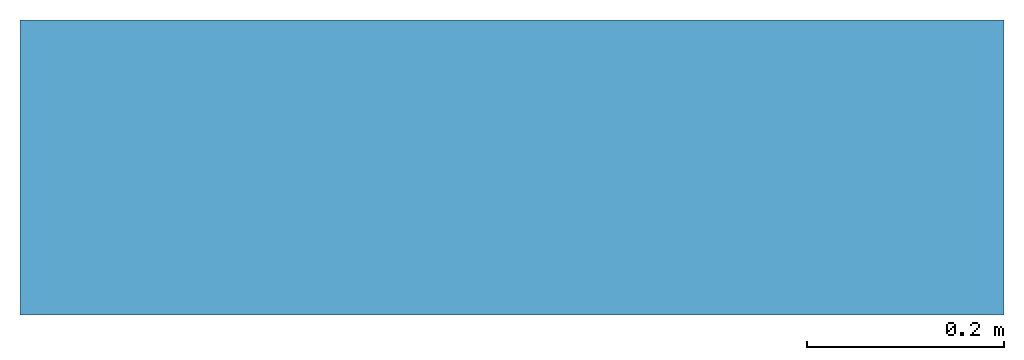
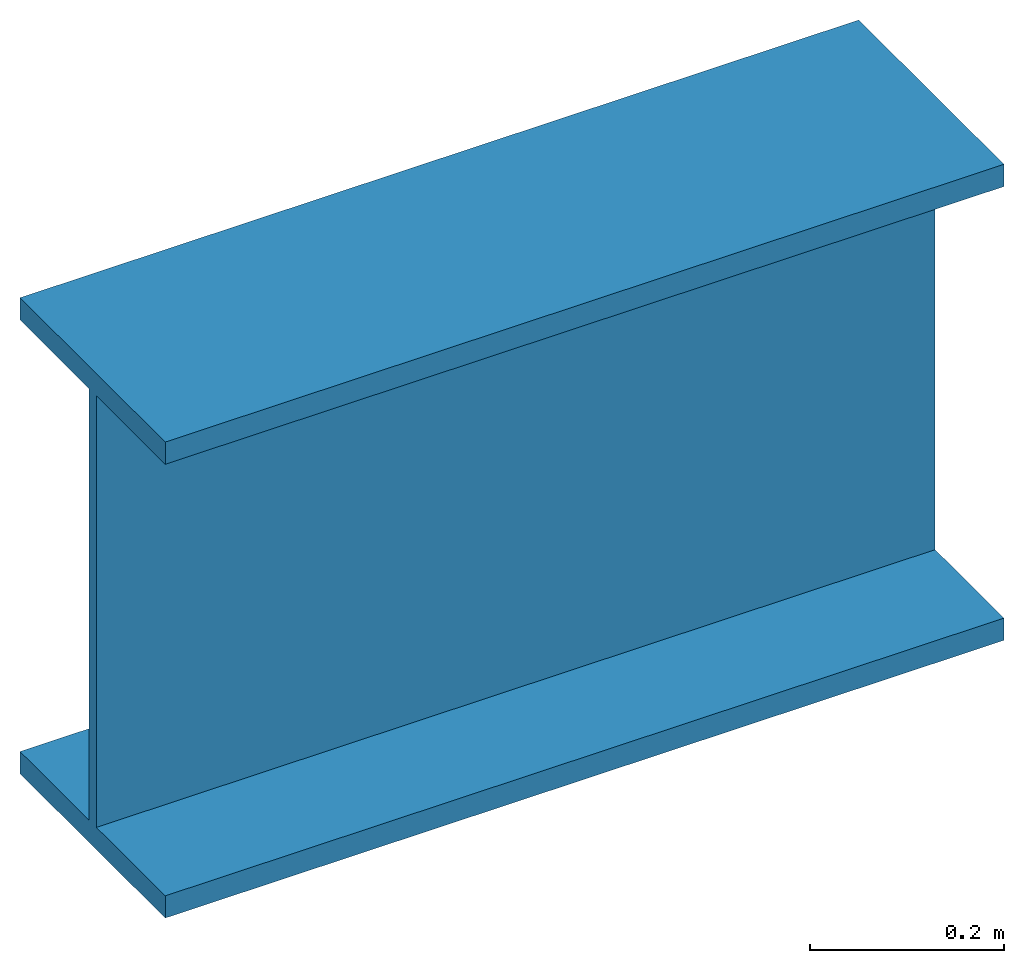
# Not in any storey: 1 beam.
"""IFC4 model written with IfcOpenShell, lengths in metres."""

import ifcopenshell
import ifcopenshell.guid

model = None  # the IFC model being written
_history = None  # IfcOwnerHistory: only IFC2X3 demands one
_inside = {}  # id of a spatial element -> (the spatial element, [elements in it])
_under = {}  # id of a project, library or spatial element -> (it, [spatial elements below it])
_declared = {}  # id of a project -> (the project, [libraries it declares])
_typed = {}  # id of a type object -> (the type object, [elements of that type])
_made_of = {}  # id of a material, layer set ... -> (it, [elements and type objects made of it])


def new_model(schema):
    """Start an empty IFC model of exactly this schema.

    Asked for "IFC4X3", IfcOpenShell would pick the latest addendum, in which some entities
    have other attributes; the version numbers below select the first issue.
    IFC2X3 requires an IfcOwnerHistory on every rooted entity: one is made here for all.
    """
    global model, _history
    if schema == "IFC4X3":
        model = ifcopenshell.file(schema_version=(4, 3, 0, 0))
    else:
        model = ifcopenshell.file(schema=schema)
    _inside.clear()
    _under.clear()
    _declared.clear()
    _typed.clear()
    _made_of.clear()
    _history = None
    if model.schema == "IFC2X3":
        org = make("IfcOrganization", Name="unknown")
        user = make(
            "IfcPersonAndOrganization",
            ThePerson=make("IfcPerson", FamilyName="unknown"),
            TheOrganization=org,
        )
        app = make(
            "IfcApplication",
            ApplicationDeveloper=org,
            Version="unknown",
            ApplicationFullName="unknown",
            ApplicationIdentifier="unknown",
        )
        _history = make(
            "IfcOwnerHistory",
            OwningUser=user,
            OwningApplication=app,
            ChangeAction="ADDED",
            CreationDate=0,
        )
    return model


def make(cls, **values):
    """One entity of the class cls with the attributes given. An attribute that is None is left unset."""
    return model.create_entity(
        cls, **{name: value for name, value in values.items() if value is not None}
    )


def entity(cls, *values):
    """Any entity or typed value of the class cls, its attributes in the order of the schema. None: left unset."""
    e = model.create_entity(cls)
    for i, value in enumerate(values):
        if value is not None:
            e[i] = value
    return e


def rooted(cls, **values):
    """An entity with a GlobalId (a new one), such as an element, a storey or a relation."""
    return make(cls, GlobalId=ifcopenshell.guid.new(), OwnerHistory=_history, **values)


def si_unit(unit_type, name, prefix=None):
    """IfcSIUnit, for example si_unit("LENGTHUNIT", "METRE", prefix="MILLI")."""
    return make("IfcSIUnit", UnitType=unit_type, Prefix=prefix, Name=name)


def converted_unit(unit_type, name, factor, base, dimensions=None, offset=None):
    """IfcConversionBasedUnit, such as the inch: factor (a typed value) times the base unit."""
    return make(
        "IfcConversionBasedUnit"
        if offset is None
        else "IfcConversionBasedUnitWithOffset",
        ConversionOffset=offset,
        Dimensions=None
        if dimensions is None
        else entity("IfcDimensionalExponents", *dimensions),
        UnitType=unit_type,
        Name=name,
        ConversionFactor=make(
            "IfcMeasureWithUnit", ValueComponent=factor, UnitComponent=base
        ),
    )


def derived_unit(unit_type, elements):
    """IfcDerivedUnit: a product of units, each with its exponent."""
    return make(
        "IfcDerivedUnit",
        Elements=[
            make("IfcDerivedUnitElement", Unit=unit, Exponent=power)
            for unit, power in elements
        ],
        UnitType=unit_type,
    )


def assignment(units):
    """IfcUnitAssignment: the units of a project."""
    return None if units is None else make("IfcUnitAssignment", Units=units)


def point(xyz):
    """IfcCartesianPoint."""
    return None if xyz is None else make("IfcCartesianPoint", Coordinates=xyz)


def direction(xyz):
    """IfcDirection."""
    return None if xyz is None else make("IfcDirection", DirectionRatios=xyz)


def frame(location, z_axis=None, x_axis=None):
    """IfcAxis2Placement3D, a coordinate frame: its origin and axes. An axis left out is left unset."""
    return make(
        "IfcAxis2Placement3D",
        Location=point(location),
        Axis=direction(z_axis),
        RefDirection=direction(x_axis),
    )


def frame_2d(location, x_axis=None):
    """IfcAxis2Placement2D, a coordinate frame in the plane: its origin and x axis."""
    return make(
        "IfcAxis2Placement2D", Location=point(location), RefDirection=direction(x_axis)
    )


def origin():
    """The frame at (0, 0, 0) with its axes left unset."""
    return frame((0.0, 0.0, 0.0))


def place(relative_to, where):
    """IfcLocalPlacement: puts the frame where relative to a parent placement (None: the world)."""
    return make(
        "IfcLocalPlacement", PlacementRelTo=relative_to, RelativePlacement=where
    )


def context(
    kind, dimensions, precision=None, world=None, true_north=None, identifier=None
):
    """IfcGeometricRepresentationContext, for example the 3D "Model" context."""
    return make(
        "IfcGeometricRepresentationContext",
        ContextIdentifier=identifier,
        ContextType=kind,
        CoordinateSpaceDimension=dimensions,
        Precision=precision,
        WorldCoordinateSystem=world,
        TrueNorth=true_north,
    )


def subcontext(parent, identifier, kind, view, scale=None):
    """IfcGeometricRepresentationSubContext, for example "Body" below "Model"."""
    return make(
        "IfcGeometricRepresentationSubContext",
        ContextIdentifier=identifier,
        ContextType=kind,
        ParentContext=parent,
        TargetScale=scale,
        TargetView=view,
    )


def project(units=None, contexts=None):
    """IfcProject with its units and contexts."""
    return rooted(
        "IfcProject",
        Name="project",
        RepresentationContexts=contexts,
        UnitsInContext=assignment(units),
    )


def spatial(cls, under=None, at=None, **own):
    """A site, building, storey or space (cls), placed at a placement, below another one or the project."""
    s = rooted(cls, ObjectPlacement=at, **own)
    if under is not None:
        _under.setdefault(under.id(), (under, []))[1].append(s)
    return s


def polyline(points):
    """IfcPolyline through the points."""
    return make("IfcPolyline", Points=[point(p) for p in points])


def segment(curve, same_sense, transition):
    """IfcCompositeCurveSegment."""
    return make(
        "IfcCompositeCurveSegment",
        Transition=transition,
        SameSense=same_sense,
        ParentCurve=curve,
    )


def composite_curve(segments, self_intersect=None):
    """IfcCompositeCurve: segments joined end to end."""
    return make("IfcCompositeCurve", Segments=segments, SelfIntersect=self_intersect)


def profile(cls, at=None, kind="AREA", **sizes):
    """A parametric profile (cls). Its sizes go by their IFC names, for example OverallWidth=200.0."""
    return make(cls, ProfileType=kind, Position=at, **sizes)


def i_section(**sizes):
    """IfcIShapeProfileDef."""
    return profile("IfcIShapeProfileDef", **sizes)


def outline(outer, holes=None, kind="AREA"):
    """IfcArbitraryClosedProfileDef: a profile drawn as a closed curve; with holes, ...WithVoids."""
    if holes is None:
        return make("IfcArbitraryClosedProfileDef", ProfileType=kind, OuterCurve=outer)
    return make(
        "IfcArbitraryProfileDefWithVoids",
        ProfileType=kind,
        OuterCurve=outer,
        InnerCurves=holes,
    )


def extrude(swept, where, along, depth):
    """IfcExtrudedAreaSolid: the profile swept, set in the frame where, extruded along a direction by depth."""
    return make(
        "IfcExtrudedAreaSolid",
        SweptArea=swept,
        Position=where,
        ExtrudedDirection=direction(along),
        Depth=depth,
    )


def shape(context_of_items, identifier, shape_type, items):
    """IfcShapeRepresentation: the items that make up one representation, for example the "Body"."""
    return make(
        "IfcShapeRepresentation",
        ContextOfItems=context_of_items,
        RepresentationIdentifier=identifier,
        RepresentationType=shape_type,
        Items=items,
    )


def source(mapping_origin, context_of_items, identifier, shape_type, items):
    """IfcRepresentationMap: a shape defined once, which mapped items show again and again."""
    return make(
        "IfcRepresentationMap",
        MappingOrigin=mapping_origin,
        MappedRepresentation=shape(context_of_items, identifier, shape_type, items),
    )


def transform(
    local_origin,
    x_axis=None,
    y_axis=None,
    z_axis=None,
    scale=None,
    scale2=None,
    scale3=None,
    uniform=True,
):
    """IfcCartesianTransformationOperator3D, or its non-uniform kind. x_axis, y_axis, z_axis: its Axis1, 2, 3."""
    if uniform:
        return make(
            "IfcCartesianTransformationOperator3D",
            Axis1=direction(x_axis),
            Axis2=direction(y_axis),
            LocalOrigin=point(local_origin),
            Scale=scale,
            Axis3=direction(z_axis),
        )
    return make(
        "IfcCartesianTransformationOperator3DnonUniform",
        Axis1=direction(x_axis),
        Axis2=direction(y_axis),
        LocalOrigin=point(local_origin),
        Scale=scale,
        Axis3=direction(z_axis),
        Scale2=scale2,
        Scale3=scale3,
    )


def mapped(mapping_source, mapping_target):
    """IfcMappedItem: shows the shape of a source again, moved by a transform."""
    return make(
        "IfcMappedItem", MappingSource=mapping_source, MappingTarget=mapping_target
    )


def material(Name=None, Category=None):
    """IfcMaterial."""
    return make("IfcMaterial", Name=Name, Category=Category)


def material_profile(
    of_material, cross_section, Name=None, Category=None, Priority=None
):
    """IfcMaterialProfile: a cross section and its material."""
    return make(
        "IfcMaterialProfile",
        Name=Name,
        Material=of_material,
        Profile=cross_section,
        Priority=Priority,
        Category=Category,
    )


def profile_set(profiles, Name=None, composite=None):
    """IfcMaterialProfileSet."""
    return make(
        "IfcMaterialProfileSet",
        Name=Name,
        MaterialProfiles=profiles,
        CompositeProfile=composite,
    )


def profile_usage(for_profile_set, cardinal=None, extent=None):
    """IfcMaterialProfileSetUsage: how a profile set lies along its element."""
    return make(
        "IfcMaterialProfileSetUsage",
        ForProfileSet=for_profile_set,
        CardinalPoint=cardinal,
        ReferenceExtent=extent,
    )


def made_of(thing, what):
    """Note that an element or type object is made of a material, layer set ...; save() writes the relation."""
    if what is not None:
        _made_of.setdefault(what.id(), (what, []))[1].append(thing)
    return thing


def type_object(cls, material=None, **own):
    """A type object (cls), such as IfcWallType, which elements share."""
    return made_of(rooted(cls, **own), material)


def type_shapes(of_type, sources):
    """Give a type object the sources (RepresentationMaps) that its elements show as mapped items."""
    of_type.RepresentationMaps = sources


def element(
    cls,
    number,
    at=None,
    inside=None,
    cuts=None,
    type_object=None,
    material=None,
    context=None,
    identifier="Body",
    shape_type=None,
    held_by="IfcProductDefinitionShape",
    body=None,
    shapes=None,
    **own,
):
    """One element of the class cls, such as IfcWall. Its Tag is "e" and its number.

    at: its placement. inside: the storey or other place that contains it. cuts: it is an
    opening in that element (IfcRelVoidsElement). A single representation is given by context,
    identifier, shape_type and body (its items); several are given by shapes. held_by: the class
    of the entity that holds the representations. save() writes the other relations.
    """
    e = rooted(cls, Tag="e%d" % number, ObjectPlacement=at, **own)
    if body is not None:
        shapes = [shape(context, identifier, shape_type, body)]
    if shapes is not None:
        e.Representation = make(held_by, Representations=shapes)
    if inside is not None:
        _inside.setdefault(inside.id(), (inside, []))[1].append(e)
    if cuts is not None:
        rooted(
            "IfcRelVoidsElement", RelatingBuildingElement=cuts, RelatedOpeningElement=e
        )
    if type_object is not None:
        _typed.setdefault(type_object.id(), (type_object, []))[1].append(e)
    return made_of(e, material)


def aggregate(whole, parts):
    """IfcRelAggregates: a whole, such as a stair, and the parts it consists of."""
    return rooted("IfcRelAggregates", RelatingObject=whole, RelatedObjects=parts)


def save(model, path):
    """Write the relations noted so far, then the file.

    IfcRelAggregates (storeys below a building ...), IfcRelContainedInSpatialStructure (elements
    in a storey), IfcRelDefinesByType, IfcRelAssociatesMaterial and IfcRelDeclares: one each for
    every whole, place, type object, material and project.
    """
    for whole, parts in _under.values():
        aggregate(whole, parts)
    for where, things in _inside.values():
        rooted(
            "IfcRelContainedInSpatialStructure",
            RelatedElements=things,
            RelatingStructure=where,
        )
    for kind, things in _typed.values():
        rooted("IfcRelDefinesByType", RelatedObjects=things, RelatingType=kind)
    for what, things in _made_of.values():
        rooted("IfcRelAssociatesMaterial", RelatedObjects=things, RelatingMaterial=what)
    for by, libraries in _declared.values():
        rooted("IfcRelDeclares", RelatingContext=by, RelatedDefinitions=libraries)
    model.write(path)


model = new_model("IFC4")

# Units and contexts
model_context = context("Model", 3, precision=1e-05, world=origin(), true_north=direction((6.12303176911189e-17, 1.0)))
body_context = subcontext(model_context, "Body", "Model", "MODEL_VIEW")
ifc_project = project(units=[si_unit("LENGTHUNIT", "METRE"), si_unit("AREAUNIT", "SQUARE_METRE"), si_unit("VOLUMEUNIT", "CUBIC_METRE"), converted_unit("PLANEANGLEUNIT", "DEGREE", entity("IfcRatioMeasure", 0.0174532925199433), si_unit("PLANEANGLEUNIT", "RADIAN"), dimensions=[0, 0, 0, 0, 0, 0, 0]), si_unit("MASSUNIT", "GRAM", prefix="KILO"), derived_unit("MASSDENSITYUNIT", [(si_unit("MASSUNIT", "GRAM", prefix="KILO"), 1), (si_unit("LENGTHUNIT", "METRE"), -3)]), derived_unit("MOMENTOFINERTIAUNIT", [(si_unit("LENGTHUNIT", "METRE"), 4)]), si_unit("TIMEUNIT", "SECOND"), si_unit("FREQUENCYUNIT", "HERTZ"), si_unit("THERMODYNAMICTEMPERATUREUNIT", "DEGREE_CELSIUS"), derived_unit("THERMALTRANSMITTANCEUNIT", [(si_unit("MASSUNIT", "GRAM", prefix="KILO"), 1), (si_unit("THERMODYNAMICTEMPERATUREUNIT", "KELVIN"), -1), (si_unit("TIMEUNIT", "SECOND"), -3)]), derived_unit("VOLUMETRICFLOWRATEUNIT", [(si_unit("LENGTHUNIT", "METRE"), 3), (si_unit("TIMEUNIT", "SECOND"), -1)]), si_unit("ELECTRICCURRENTUNIT", "AMPERE"), si_unit("ELECTRICVOLTAGEUNIT", "VOLT"), si_unit("POWERUNIT", "WATT"), si_unit("FORCEUNIT", "NEWTON", prefix="KILO"), si_unit("ILLUMINANCEUNIT", "LUX"), si_unit("LUMINOUSFLUXUNIT", "LUMEN"), si_unit("LUMINOUSINTENSITYUNIT", "CANDELA"), derived_unit("USERDEFINED", [(si_unit("MASSUNIT", "GRAM", prefix="KILO"), -1), (si_unit("LENGTHUNIT", "METRE"), -2), (si_unit("TIMEUNIT", "SECOND"), 3), (si_unit("LUMINOUSFLUXUNIT", "LUMEN"), 1)]), derived_unit("LINEARVELOCITYUNIT", [(si_unit("LENGTHUNIT", "METRE"), 1), (si_unit("TIMEUNIT", "SECOND"), -1)]), si_unit("PRESSUREUNIT", "PASCAL"), derived_unit("USERDEFINED", [(si_unit("LENGTHUNIT", "METRE"), -2), (si_unit("MASSUNIT", "GRAM", prefix="KILO"), 1), (si_unit("TIMEUNIT", "SECOND"), -2)]), derived_unit("LINEARFORCEUNIT", [(si_unit("MASSUNIT", "GRAM", prefix="KILO"), 1), (si_unit("LENGTHUNIT", "METRE"), 1), (si_unit("TIMEUNIT", "SECOND"), -2), (si_unit("LENGTHUNIT", "METRE"), -1)]), derived_unit("PLANARFORCEUNIT", [(si_unit("MASSUNIT", "GRAM", prefix="KILO"), 1), (si_unit("LENGTHUNIT", "METRE"), 1), (si_unit("TIMEUNIT", "SECOND"), -2), (si_unit("LENGTHUNIT", "METRE"), -2)])], contexts=[model_context])

# Site
site_placement = place(None, origin())
site = spatial("IfcSite", under=ifc_project, at=site_placement, CompositionType="ELEMENT")

# Beam
ifc_material = material()
ifc_material_profile_1 = material_profile(ifc_material, outline(composite_curve([segment(polyline([(-0.150000000000002, -0.0280000000000009, 0.0), (-0.150000000000002, 0.0, 0.0)]), True, "CONTINUOUS"), segment(polyline([(-0.150000000000002, 0.0, 0.0), (0.149999999999997, 0.0, 0.0)]), True, "CONTINUOUS"), segment(polyline([(0.149999999999997, 0.0, 0.0), (0.149999999999997, -0.0280000000000005, 0.0)]), True, "CONTINUOUS"), segment(polyline([(0.149999999999997, -0.0280000000000005, 0.0), (0.00774999999999604, -0.0280000000000005, 0.0)]), True, "CONTINUOUS"), segment(polyline([(0.00774999999999604, -0.0280000000000005, 0.0), (0.00774999999999604, -0.571999999999997, 0.0)]), True, "CONTINUOUS"), segment(polyline([(0.00774999999999604, -0.571999999999997, 0.0), (0.149999999999994, -0.571999999999997, 0.0)]), True, "CONTINUOUS"), segment(polyline([(0.149999999999994, -0.571999999999997, 0.0), (0.149999999999994, -0.600000000000001, 0.0)]), True, "CONTINUOUS"), segment(polyline([(0.149999999999994, -0.600000000000001, 0.0), (-0.150000000000005, -0.600000000000001, 0.0)]), True, "CONTINUOUS"), segment(polyline([(-0.150000000000005, -0.600000000000001, 0.0), (-0.150000000000005, -0.572000000000001, 0.0)]), True, "CONTINUOUS"), segment(polyline([(-0.150000000000005, -0.572000000000001, 0.0), (-0.00775000000000259, -0.572000000000001, 0.0)]), True, "CONTINUOUS"), segment(polyline([(-0.00775000000000259, -0.572000000000001, 0.0), (-0.00775000000000259, -0.0280000000000009, 0.0)]), True, "CONTINUOUS"), segment(polyline([(-0.00775000000000259, -0.0280000000000009, 0.0), (-0.150000000000002, -0.0280000000000009, 0.0)]), True, "CONTINUOUS")], self_intersect=False), kind="CURVE"), Name="HEB 600")
ifc_material_profile_2 = material_profile(ifc_material, outline(composite_curve([segment(polyline([(-0.500000000000001, -0.150000000000002, 0.0), (-0.500000000000001, 0.149999999999998, 0.0)]), True, "CONTINUOUS"), segment(polyline([(-0.500000000000001, 0.149999999999998, 0.0), (-0.500000000000001, 0.149999999999998, -0.0280000000000005)]), True, "CONTINUOUS"), segment(polyline([(-0.500000000000001, 0.149999999999998, -0.0280000000000005), (-0.500000000000001, 0.00774999999999631, -0.0280000000000005)]), True, "CONTINUOUS"), segment(polyline([(-0.500000000000001, 0.00774999999999631, -0.0280000000000005), (-0.500000000000001, 0.00774999999999631, -0.571999999999997)]), True, "CONTINUOUS"), segment(polyline([(-0.500000000000001, 0.00774999999999631, -0.571999999999997), (-0.500000000000001, 0.149999999999995, -0.571999999999997)]), True, "CONTINUOUS"), segment(polyline([(-0.500000000000001, 0.149999999999995, -0.571999999999997), (-0.500000000000001, 0.149999999999995, -0.600000000000001)]), True, "CONTINUOUS"), segment(polyline([(-0.500000000000001, 0.149999999999995, -0.600000000000001), (-0.500000000000001, -0.150000000000004, -0.600000000000001)]), True, "CONTINUOUS"), segment(polyline([(-0.500000000000001, -0.150000000000004, -0.600000000000001), (-0.500000000000001, -0.150000000000004, -0.572000000000001)]), True, "CONTINUOUS"), segment(polyline([(-0.500000000000001, -0.150000000000004, -0.572000000000001), (-0.500000000000001, -0.00775000000000232, -0.572000000000001)]), True, "CONTINUOUS"), segment(polyline([(-0.500000000000001, -0.00775000000000232, -0.572000000000001), (-0.500000000000001, -0.00775000000000232, -0.0280000000000009)]), True, "CONTINUOUS"), segment(polyline([(-0.500000000000001, -0.00775000000000232, -0.0280000000000009), (-0.500000000000001, -0.150000000000002, -0.0280000000000009)]), True, "CONTINUOUS"), segment(polyline([(-0.500000000000001, -0.150000000000002, -0.0280000000000009), (-0.500000000000001, -0.150000000000002, 0.0)]), True, "CONTINUOUS")], self_intersect=False), kind="CURVE"), Name="HEB 600")
ifc_profile_set = profile_set([ifc_material_profile_1, ifc_material_profile_2], Name="HEB 600")
ifc_profile_usage = profile_usage(ifc_profile_set, cardinal=8)
beam_type = type_object("IfcBeamType", Name="HEB 600", PredefinedType="BEAM", material=ifc_profile_set)
shared_shape = source(origin(), body_context, "Body", "SweptSolid", [
    extrude(i_section(OverallWidth=0.299999999999999, OverallDepth=0.599999999999999, WebThickness=0.0155000000000013, FlangeThickness=0.0280000000000048, at=frame_2d((-7.49400541621981e-16, -4.16333634234434e-16), x_axis=(0.0, 1.0))), frame((-0.500000000000001, 0.0, -0.3), z_axis=(1.0, 0.0, 0.0), x_axis=(0.0, 0.0, -1.0)), (0.0, 0.0, 1.0), 1.0),
])
type_shapes(beam_type, [shared_shape])
beam_placement = place(site_placement, frame((0.468202796647807, -1.57542478255666, 0.0)))
element("IfcBeam", 1, at=beam_placement, inside=site, type_object=beam_type, material=ifc_profile_usage, PredefinedType="BEAM", context=body_context, shape_type="MappedRepresentation", body=[
    mapped(shared_shape, transform((0.0, 0.0, 0.0), scale=1.0)),
])

save(model, "model.ifc")
